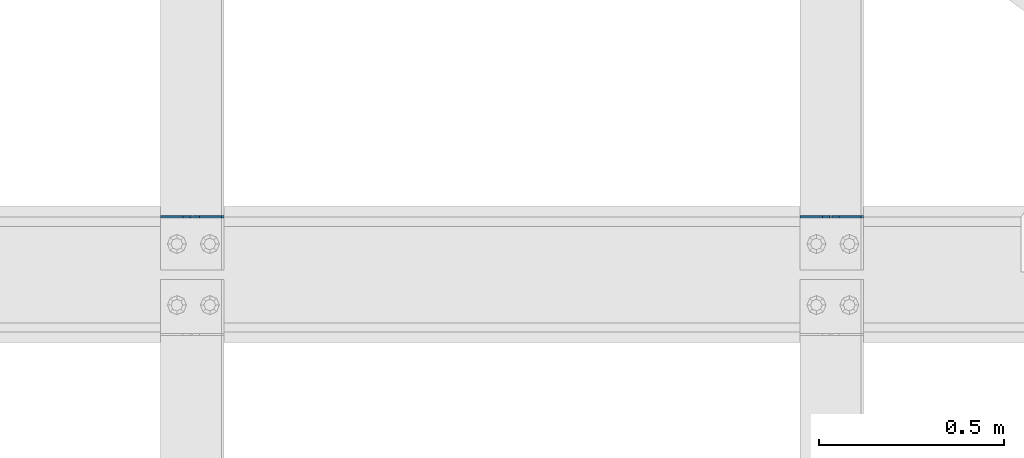
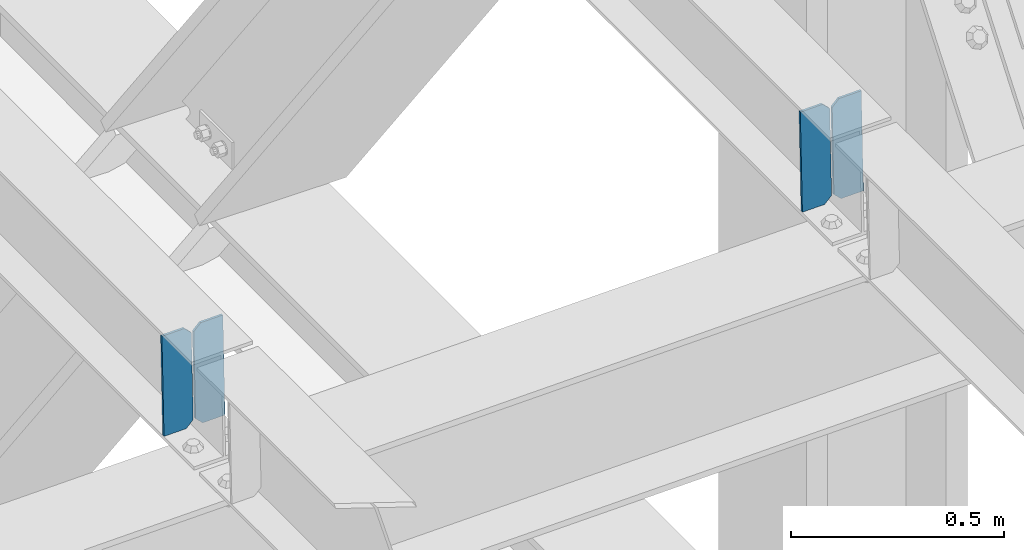
# One storey, part 3577 of 3843: 4 plates, 2 elements without a shape of their own.
"""IFC2X3 building model written with IfcOpenShell, lengths in millimetres."""

from ifc_helpers import new_model, si_unit, frame, origin_with_axes, place, context, subcontext, project, spatial, faceted_brep, material, type_object, element, aggregate, save


model = new_model("IFC2X3")

# Units and contexts
model_context = context("Model", 3, precision=1e-05, world=origin_with_axes())
body_context = subcontext(model_context, "Body", "Model", "MODEL_VIEW")
ifc_project = project(units=[si_unit("LENGTHUNIT", "METRE", prefix="MILLI"), si_unit("AREAUNIT", "SQUARE_METRE"), si_unit("VOLUMEUNIT", "CUBIC_METRE"), si_unit("MASSUNIT", "GRAM", prefix="KILO"), si_unit("TIMEUNIT", "SECOND"), si_unit("PLANEANGLEUNIT", "RADIAN"), si_unit("SOLIDANGLEUNIT", "STERADIAN"), si_unit("THERMODYNAMICTEMPERATUREUNIT", "DEGREE_CELSIUS"), si_unit("LUMINOUSINTENSITYUNIT", "LUMEN")], contexts=[model_context])

# Site, building, storey
site_placement = place(None, origin_with_axes())
site = spatial("IfcSite", under=ifc_project, at=site_placement, CompositionType="ELEMENT")
building_placement = place(site_placement, origin_with_axes())
building = spatial("IfcBuilding", under=site, at=building_placement, Name="Undefined", CompositionType="ELEMENT")
storey_placement = place(building_placement, origin_with_axes())
storey = spatial("IfcBuildingStorey", under=building, at=storey_placement, Name="Undefined", CompositionType="ELEMENT", Elevation=0.0)

# Assembly, plates
assembly_1_placement = place(storey_placement, origin_with_axes())
assembly_1 = element("IfcElementAssembly", 1, at=assembly_1_placement, inside=storey, Name="BEAM", AssemblyPlace="NOTDEFINED", PredefinedType="RIGID_FRAME")
ifc_material = material(Name="STEEL/A572-50")
plate_type = type_object("IfcPlateType", PredefinedType="NOTDEFINED")
plate_1_placement = place(assembly_1_placement, frame((84003.8964783504, 25772.2940572233, 46433.3442186391), z_axis=(-0.0211520980156492, -0.0027498239992492, 0.999772487727838), x_axis=(-0.999776269347066, 5.81780000294847e-05, -0.0211520180073662)))
plate_1 = element("IfcPlate", 2, at=plate_1_placement, type_object=plate_type, material=ifc_material, Name="PLATE", context=body_context, shape_type="Brep", body=[
    faceted_brep([(0.0, -3.17499999999927, 0.0), (6.83940015733242e-10, -3.17499999996653, 288.924999998613), (6.54836185276508e-10, 3.17500000001746, 288.924999998591), (0.0, 3.17499999999927, 0.0), (60.3250007643655, -3.17500000017753, 288.924999998606), (60.3250007643219, 3.17499999979918, 288.924999998584), (79.3750000013097, -3.17500000025029, 269.875000761494), (79.375000001266, 3.17499999972642, 269.875000761487), (79.375000000713, -3.17500000026484, 19.0499992370605), (79.3750000006985, 3.17499999971187, 19.0499992370533), (60.325000763667, -3.17500000020664, -1.45519152283669e-11), (60.3250007636234, 3.17499999977736, -3.63797880709171e-11)], [[[0, 1, 2, 3]], [[1, 4, 5, 2]], [[4, 6, 7, 5]], [[6, 8, 9, 7]], [[8, 10, 11, 9]], [[10, 0, 3, 11]], [[5, 7, 9, 11, 3, 2]], [[10, 8, 6, 4, 1, 0]]]),
])
plate_2_placement = place(assembly_1_placement, frame((83918.1906576601, 25772.2990444937, 46431.5309618971), z_axis=(-0.0211520980156492, -0.0027498239992492, 0.999772487727838), x_axis=(-0.999776269347066, 5.81780000294847e-05, -0.0211520180073662)))
plate_2 = element("IfcPlate", 3, at=plate_2_placement, type_object=plate_type, material=ifc_material, Name="PLATE", context=body_context, shape_type="Brep", body=[
    faceted_brep([(4.36557456851006e-11, -3.17499999998836, 19.0499992370969), (6.11180439591408e-10, -3.17499999996653, 269.875000761516), (5.96628524363041e-10, 3.17500000001746, 269.875000761502), (1.45519152283669e-11, 3.17499999998836, 19.0499992370824), (19.0499992376572, -3.17500000003201, 288.924999998606), (19.0499992376281, 3.1749999999447, 288.924999998584), (79.3750000013242, -3.17500000025029, 288.924999998591), (79.3750000013097, 3.1749999997337, 288.92499999857), (79.3750000006548, -3.17500000026484, -2.18278728425503e-11), (79.3750000006403, 3.17499999969732, -2.91038304567337e-11), (19.0499992370023, -3.17500000005384, 0.0), (19.0499992369587, 3.17499999992287, -1.45519152283669e-11)], [[[0, 1, 2, 3]], [[1, 4, 5, 2]], [[4, 6, 7, 5]], [[6, 8, 9, 7]], [[8, 10, 11, 9]], [[10, 0, 3, 11]], [[5, 7, 9, 11, 3, 2]], [[10, 8, 6, 4, 1, 0]]]),
])
aggregate(assembly_1, [plate_1, plate_2])

assembly_2_placement = place(storey_placement, origin_with_axes())
assembly_2 = element("IfcElementAssembly", 4, at=assembly_2_placement, inside=storey, Name="BEAM", AssemblyPlace="NOTDEFINED", PredefinedType="RIGID_FRAME")
plate_3_placement = place(assembly_2_placement, frame((82276.6964783502, 25772.2564162163, 46396.7822402907), z_axis=(-0.0211520978195331, -0.0026232759994382, 0.999772827786825), x_axis=(-0.999776269351215, 5.55000000252694e-05, -0.0211520250074752)))
plate_3 = element("IfcPlate", 5, at=plate_3_placement, type_object=plate_type, material=ifc_material, Name="PLATE", context=body_context, shape_type="Brep", body=[
    faceted_brep([(0.0, -3.17499999999927, 0.0), (6.83940015733242e-10, -3.17499999996653, 288.924999998613), (6.54836185276508e-10, 3.17500000001746, 288.924999998591), (0.0, 3.17499999999927, 0.0), (60.3250007643655, -3.17500000017753, 288.924999998606), (60.3250007643219, 3.17499999979918, 288.924999998584), (79.3750000013097, -3.17500000025029, 269.875000761494), (79.375000001266, 3.17499999972642, 269.875000761487), (79.375000000713, -3.17500000026484, 19.0499992370605), (79.3750000006985, 3.17499999971187, 19.0499992370533), (60.325000763667, -3.17500000020664, -1.45519152283669e-11), (60.3250007636234, 3.17499999977736, -3.63797880709171e-11)], [[[0, 1, 2, 3]], [[1, 4, 5, 2]], [[4, 6, 7, 5]], [[6, 8, 9, 7]], [[8, 10, 11, 9]], [[10, 0, 3, 11]], [[5, 7, 9, 11, 3, 2]], [[10, 8, 6, 4, 1, 0]]]),
])
plate_4_placement = place(assembly_2_placement, frame((82190.9906576599, 25772.2611739716, 46394.9689829317), z_axis=(-0.0211520978195331, -0.0026232759994382, 0.999772827786825), x_axis=(-0.999776269351215, 5.55000000252694e-05, -0.0211520250074752)))
plate_4 = element("IfcPlate", 6, at=plate_4_placement, type_object=plate_type, material=ifc_material, Name="PLATE", context=body_context, shape_type="Brep", body=[
    faceted_brep([(4.36557456851006e-11, -3.17499999998836, 19.0499992370969), (6.11180439591408e-10, -3.17499999996653, 269.875000761516), (5.96628524363041e-10, 3.17500000001746, 269.875000761502), (1.45519152283669e-11, 3.17499999998836, 19.0499992370824), (19.0499992376572, -3.17500000003201, 288.924999998606), (19.0499992376281, 3.1749999999447, 288.924999998584), (79.3750000013242, -3.17500000025029, 288.924999998591), (79.3750000013097, 3.1749999997337, 288.92499999857), (79.3750000006548, -3.17500000026484, -2.18278728425503e-11), (79.3750000006403, 3.17499999969732, -2.91038304567337e-11), (19.0499992370023, -3.17500000005384, 0.0), (19.0499992369587, 3.17499999992287, -1.45519152283669e-11)], [[[0, 1, 2, 3]], [[1, 4, 5, 2]], [[4, 6, 7, 5]], [[6, 8, 9, 7]], [[8, 10, 11, 9]], [[10, 0, 3, 11]], [[5, 7, 9, 11, 3, 2]], [[10, 8, 6, 4, 1, 0]]]),
])
aggregate(assembly_2, [plate_3, plate_4])

save(model, "model.ifc")
